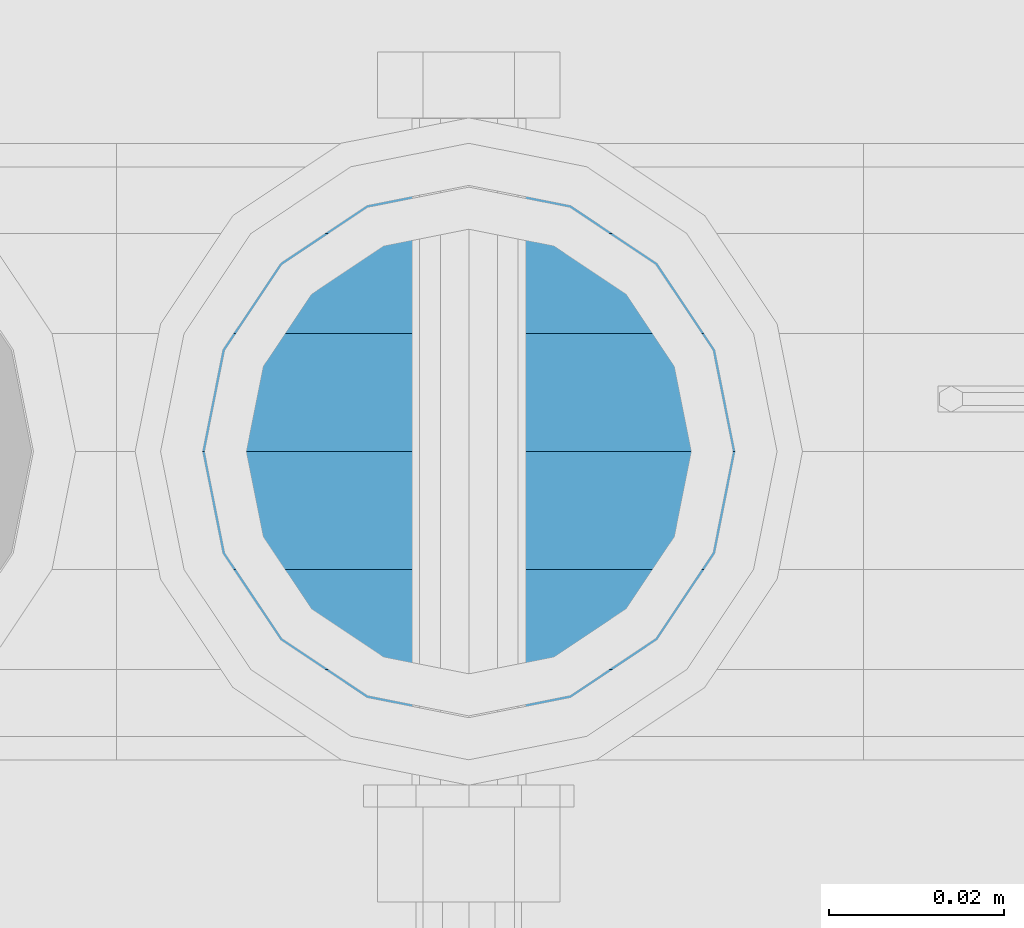
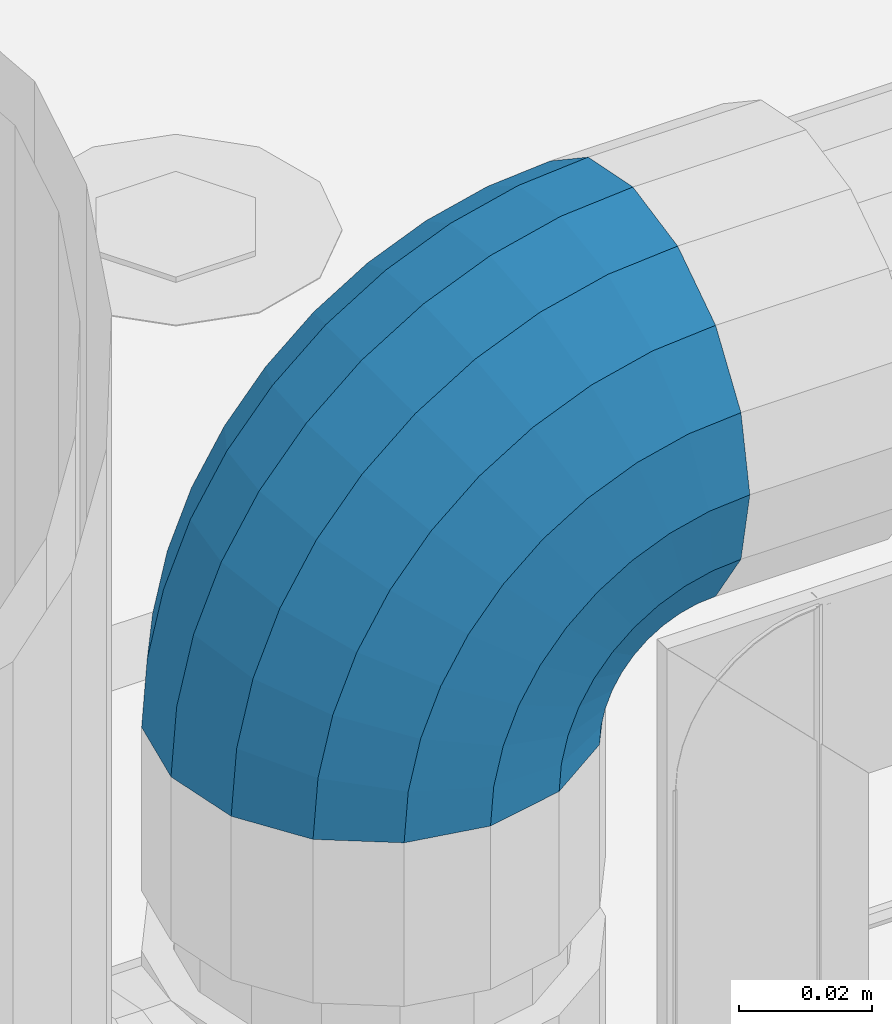
# One storey, part 146 of 247: 1 member.
"""IFC2X3 building model written with IfcOpenShell, lengths in millimetres."""

from ifc_helpers import new_model, si_unit, frame, origin_with_axes, place, context, subcontext, project, spatial, faceted_brep, material, type_object, element, save


model = new_model("IFC2X3")

# Units and contexts
model_context = context("Model", 3, precision=1e-05, world=origin_with_axes())
body_context = subcontext(model_context, "Body", "Model", "MODEL_VIEW")
ifc_project = project(units=[si_unit("LENGTHUNIT", "METRE", prefix="MILLI"), si_unit("AREAUNIT", "SQUARE_METRE"), si_unit("VOLUMEUNIT", "CUBIC_METRE"), si_unit("MASSUNIT", "GRAM", prefix="KILO"), si_unit("TIMEUNIT", "SECOND"), si_unit("PLANEANGLEUNIT", "RADIAN"), si_unit("SOLIDANGLEUNIT", "STERADIAN"), si_unit("THERMODYNAMICTEMPERATUREUNIT", "DEGREE_CELSIUS"), si_unit("LUMINOUSINTENSITYUNIT", "LUMEN")], contexts=[model_context])

# Site, building, storey
site_placement = place(None, origin_with_axes())
site = spatial("IfcSite", under=ifc_project, at=site_placement, CompositionType="ELEMENT")
building_placement = place(site_placement, origin_with_axes())
building = spatial("IfcBuilding", under=site, at=building_placement, Name="Standard", CompositionType="ELEMENT")
storey_placement = place(building_placement, origin_with_axes())
storey = spatial("IfcBuildingStorey", under=building, at=storey_placement, Name="Undefined", CompositionType="ELEMENT", Elevation=0.0)

# Member
ifc_material = material(Name="Misc_Undefined")
member_type = type_object("IfcMemberType", PredefinedType="NOTDEFINED")
member_placement = place(storey_placement, frame((621.0, 7664.5, 924.849999999999), z_axis=(-0.707106789186492, 3.85000008583224e-07, 0.707106773186498), x_axis=(0.707106781186548, 0.0, 0.707106781186547)))
element("IfcMember", 1, at=member_placement, inside=storey, type_object=member_type, material=ifc_material, context=body_context, shape_type="Brep", body=[
    faceted_brep([(0.0, -35.1499999999996, 0.0), (9.51152146007007, -32.4743655677721, -9.51152146007007), (13.2759578763416, -32.4743655677721, -6.29638902527768), (5.36946880023424, -35.1499999999996, 4.58595959347804), (17.5750000000007, -24.8548033587067, -17.5750000000007), (19.9787556631127, -24.8548033587067, -15.5219987155633), (22.9628441077039, -13.4513226476329, -22.962844107702), (24.4574219585265, -13.4513226476329, -21.6863540323957), (24.8548033587067, 0.0, -24.8548033587067), (26.0301204183143, 0.0, -23.8509877588021), (22.9628441077039, 13.4513226476329, -22.962844107702), (24.4574219585265, 13.4513226476329, -21.6863540323957), (17.5750000000007, 24.8548033587067, -17.5750000000007), (19.9787556631127, 24.8548033587067, -15.5219987155633), (9.51152146007007, 32.4743655677721, -9.51152146007007), (13.2759578763416, 32.4743655677721, -6.29638902527768), (0.0, 35.1499999999996, 0.0), (5.36946880023424, 35.1499999999996, 4.58595959347804), (-9.51152146007007, 32.4743655677721, 9.51152146007007), (-2.53702027587133, 32.4743655677721, 15.4683082122338), (-17.5749999999989, 24.8548033587067, 17.5749999999989), (-9.23981806264237, 24.8548033587067, 24.6939179025194), (-22.962844107702, 13.4513226476329, 22.962844107702), (-13.718484358058, 13.4513226476329, 30.8582732193499), (-24.8548033587067, 0.0, 24.8548033587067), (-15.2911828178458, 0.0, 33.0229069457564), (-22.962844107702, -13.4513226476329, 22.962844107702), (-13.718484358058, -13.4513226476329, 30.8582732193499), (-17.5749999999989, -24.8548033587067, 17.5749999999989), (-9.23981806264237, -24.8548033587067, 24.6939179025194), (-9.51152146007007, -32.4743655677721, 9.51152146007007), (-2.53702027587133, -32.4743655677721, 15.4683082122338), (0.0, -30.3500000000004, 0.0), (-8.21265081971796, -28.0397438117179, 8.21265081971796), (-1.45732902223608, -28.0397438117179, 13.9822406910371), (5.36946880023424, -30.3500000000004, 4.58595959347804), (-15.1749999999993, -21.4606908090118, 15.1749999999993), (-7.24480876131202, -21.4606908090118, 21.948023168994), (-19.8270929919981, -11.6144421722802, 19.827092992), (-11.1118790903529, -11.6144421722802, 27.2705888550772), (-21.4606908090118, 0.0, 21.4606908090118), (-12.4698136068437, 0.0, 29.139625372758), (-19.8270929919981, 11.6144421722802, 19.827092992), (-11.1118790903529, 11.6144421722802, 27.2705888550772), (-15.1749999999993, 21.4606908090118, 15.1749999999993), (-7.24480876131202, 21.4606908090118, 21.948023168994), (-8.21265081971796, 28.0397438117179, 8.21265081971796), (-1.45732902223608, 28.0397438117179, 13.9822406910371), (0.0, 30.3500000000004, 0.0), (5.36946880023424, 30.3500000000004, 4.58595959347804), (8.21265081971978, 28.0397438117179, -8.21265081971796), (12.1962666227046, 28.0397438117179, -4.81032150408282), (15.1750000000011, 21.4606908090118, -15.1750000000011), (17.9837463617787, 21.4606908090118, -12.776103982038), (19.827092992, 11.6144421722802, -19.827092992), (21.8508166908214, 11.6144421722802, -18.0986696681211), (21.4606908090118, 0.0, -21.4606908090118), (23.2087512073122, 0.0, -19.9677061858038), (19.827092992, -11.6144421722802, -19.827092992), (21.8508166908214, -11.6144421722802, -18.0986696681211), (15.1750000000011, -21.4606908090118, -15.1750000000011), (17.9837463617787, -21.4606908090118, -12.776103982038), (8.21265081971978, -28.0397438117179, -8.21265081971796), (12.1962666227046, -28.0397438117179, -4.81032150408282), (17.4970053560719, -32.4743655677721, -3.70972780292141), (11.3902326651169, -35.1499999999996, 8.27548843508157), (22.6740772628636, -24.8548033587067, -13.8703035149447), (26.1332861179544, -13.4513226476329, -20.6593831546816), (27.347998730962, 0.0, -23.0433908901377), (26.1332861179544, 13.4513226476329, -20.6593831546816), (22.6740772628636, 24.8548033587067, -13.8703035149447), (17.4970053560719, 32.4743655677721, -3.70972780292141), (11.3902326651169, 35.1499999999996, 8.27548843508157), (5.28345997416, 32.4743655677721, 20.2607046730845), (0.106388067368243, 24.8548033587067, 30.4212803851096), (-3.3528207877207, 13.4513226476329, 37.2103600248429), (-4.56753340072828, 0.0, 39.5943677603027), (-3.3528207877207, -13.4513226476329, 37.2103600248429), (0.106388067368243, -24.8548033587067, 30.4212803851096), (5.28345997416, -32.4743655677721, 20.2607046730845), (6.11738625912767, -28.0397438117179, 18.6240321853929), (11.3902326651169, -30.3500000000004, 8.27548843508157), (1.64728291997744, -21.4606908090118, 27.3971039594999), (-1.33954464053386, -11.6144421722802, 33.2590831078905), (-2.38837900197905, 0.0, 35.3175364441977), (-1.33954464053386, 11.6144421722802, 33.2590831078905), (1.64728291997744, 21.4606908090118, 27.3971039594999), (6.11738625912767, 28.0397438117179, 18.6240321853929), (11.3902326651169, 30.3500000000004, 8.27548843508157), (16.663079071106, 28.0397438117179, -2.07305531522979), (21.1331824102544, 21.4606908090118, -10.8461270893367), (24.1200099707676, 11.6144421722802, -16.7081062377292), (25.1688443322109, 0.0, -18.7665595740345), (24.1200099707676, -11.6144421722802, -16.7081062377292), (21.1331824102544, -21.4606908090118, -10.8461270893367), (16.663079071106, -28.0397438117179, -2.07305531522979), (22.0707277014626, -32.4743655677721, -1.81522997693355), (17.9140404065238, -35.1499999999996, 10.9777380798878), (25.5945970362118, -24.8548033587067, -12.6605846156472), (27.9491712485105, -13.4513226476329, -19.9072189058952), (28.7759877588032, 0.0, -22.4518984678889), (27.9491712485105, 13.4513226476329, -19.9072189058952), (25.5945970362118, 24.8548033587067, -12.6605846156472), (22.0707277014626, 32.4743655677721, -1.81522997693355), (17.9140404065238, 35.1499999999996, 10.9777380798878), (13.757353111585, 32.4743655677721, 23.7707061367073), (10.2334837768358, 24.8548033587067, 34.6160607754209), (7.87890956453703, 13.4513226476329, 41.8626950656671), (7.05209305424432, 0.0, 44.4073746276608), (7.87890956453703, -13.4513226476329, 41.8626950656671), (10.2334837768358, -24.8548033587067, 34.6160607754209), (13.757353111585, -32.4743655677721, 23.7707061367073), (14.3249803951039, -28.0397438117179, 22.0237289909692), (17.9140404065238, -30.3500000000004, 10.9777380798878), (11.2823222355109, -21.4606908090118, 31.3880679179929), (9.24928305078174, -11.6144421722802, 37.6451191472679), (8.53537462724307, 0.0, 39.8423033494455), (9.24928305078174, 11.6144421722802, 37.6451191472679), (11.2823222355109, 21.4606908090118, 31.3880679179929), (14.3249803951039, 28.0397438117179, 22.0237289909692), (17.9140404065238, 30.3500000000004, 10.9777380798878), (21.5031004179418, 28.0397438117179, -0.0682528311936039), (24.5457585775348, 21.4606908090118, -9.43259175821731), (26.578797762264, 11.6144421722802, -15.6896429874942), (27.2927061858027, 0.0, -17.8868271896699), (26.578797762264, -11.6144421722802, -15.6896429874942), (24.5457585775348, -21.4606908090118, -9.43259175821731), (21.5031004179418, -28.0397438117179, -0.0682528311936039), (26.884504689051, -32.4743655677721, -0.65954437126311), (24.7802542265854, -35.1499999999996, 12.6261701733856), (28.6684020936846, -24.8548033587067, -11.9226293117936), (29.8603642317012, -13.4513226476329, -19.4483820661262), (30.2789256727501, 0.0, -22.0910749985342), (29.8603642317012, 13.4513226476329, -19.4483820661262), (28.6684020936846, 24.8548033587067, -11.9226293117936), (26.884504689051, 32.4743655677721, -0.65954437126311), (24.7802542265854, 35.1499999999996, 12.6261701733856), (22.6760037641197, 32.4743655677721, 25.9118847180362), (20.8921063594862, 24.8548033587067, 37.1749696585666), (19.7001442214696, 13.4513226476329, 44.7007224128993), (19.2815827804206, 0.0, 47.3434153453054), (19.7001442214696, -13.4513226476329, 44.7007224128993), (20.8921063594862, -24.8548033587067, 37.1749696585666), (22.6760037641197, -32.4743655677721, 25.9118847180362), (22.9633551786228, -28.0397438117179, 24.097619289465), (24.7802542265854, -30.3500000000004, 12.6261701733856), (21.4230625404816, -21.4606908090118, 33.8226442665655), (20.3938719035341, -11.6144421722802, 40.3206982094944), (20.0324682126138, 0.0, 42.6025113104479), (20.3938719035341, 11.6144421722802, 40.3206982094944), (21.4230625404816, 21.4606908090118, 33.8226442665655), (22.9633551786228, 28.0397438117179, 24.097619289465), (24.7802542265854, 30.3500000000004, 12.6261701733856), (26.5971532745461, 28.0397438117179, 1.15472105730987), (28.1374459126855, 21.4606908090118, -8.5703039197906), (29.1666365496367, 11.6144421722802, -15.0683578627213), (29.5280402405569, 0.0, -17.3501709636766), (29.1666365496367, -11.6144421722802, -15.0683578627213), (28.1374459126855, -21.4606908090118, -8.5703039197906), (26.5971532745461, -28.0397438117179, 1.15472105730987), (31.8198051533964, -32.4743655677721, -0.271127801028342), (31.8198051533946, -35.1499999999996, 13.1801948466054), (31.8198051533964, -24.8548033587067, -11.6746085121031), (31.8198051533964, -13.4513226476329, -19.2941707211648), (31.8198051533964, 0.0, -21.969805153396), (31.8198051533964, 13.4513226476329, -19.2941707211648), (31.8198051533964, 24.8548033587067, -11.6746085121031), (31.8198051533964, 32.4743655677721, -0.271127801028342), (31.8198051533946, 35.1499999999996, 13.1801948466054), (31.8198051533946, 32.4743655677721, 26.6315174942392), (31.8198051533946, 24.8548033587067, 38.0349982053121), (31.8198051533964, 13.4513226476329, 45.6545604143757), (31.8198051533964, 0.0, 48.3301948466033), (31.8198051533964, -13.4513226476329, 45.6545604143757), (31.8198051533946, -24.8548033587067, 38.0349982053121), (31.8198051533946, -32.4743655677721, 26.6315174942392), (31.8198051533964, -28.0397438117179, 24.7946370188838), (31.8198051533946, -30.3500000000004, 13.1801948466054), (31.8198051533964, -21.4606908090118, 34.6408856556172), (31.8198051533946, -11.6144421722802, 41.2199386583234), (31.8198051533964, 0.0, 43.530194846604), (31.8198051533946, 11.6144421722802, 41.2199386583234), (31.8198051533964, 21.4606908090118, 34.6408856556172), (31.8198051533964, 28.0397438117179, 24.7946370188838), (31.8198051533946, 30.3500000000004, 13.1801948466054), (31.8198051533964, 28.0397438117179, 1.56575267432345), (31.8198051533964, 21.4606908090118, -8.28049596240635), (31.8198051533946, 11.6144421722802, -14.8595489651125), (31.8198051533964, 0.0, -17.1698051533949), (31.8198051533946, -11.6144421722802, -14.8595489651125), (31.8198051533964, -21.4606908090118, -8.28049596240635), (31.8198051533964, -28.0397438117179, 1.56575267432345), (36.7551056177399, -32.4743655677721, -0.659544371264928), (38.8593560802055, -35.1499999999996, 12.6261701733874), (34.9712082131082, -24.8548033587067, -11.9226293117936), (33.7792460750934, -13.4513226476329, -19.4483820661262), (33.3606846340426, 0.0, -22.0910749985342), (33.7792460750934, 13.4513226476329, -19.4483820661262), (34.9712082131082, 24.8548033587067, -11.9226293117936), (36.7551056177399, 32.4743655677721, -0.659544371264928), (38.8593560802055, 35.1499999999996, 12.6261701733874), (40.963606542673, 32.4743655677721, 25.9118847180362), (42.7475039473047, 24.8548033587067, 37.1749696585666), (43.9394660853195, 13.4513226476329, 44.7007224128993), (44.3580275263703, 0.0, 47.3434153453054), (43.9394660853195, -13.4513226476329, 44.7007224128993), (42.7475039473047, -24.8548033587067, 37.1749696585666), (40.963606542673, -32.4743655677721, 25.9118847180362), (40.6762551281663, -28.0397438117179, 24.097619289465), (38.8593560802055, -30.3500000000004, 12.6261701733874), (42.2165477663093, -21.4606908090118, 33.8226442665637), (43.2457384032587, -11.6144421722802, 40.3206982094925), (43.6071420941771, 0.0, 42.6025113104497), (43.2457384032587, 11.6144421722802, 40.3206982094925), (42.2165477663093, 21.4606908090118, 33.8226442665637), (40.6762551281663, 28.0397438117179, 24.097619289465), (38.8593560802055, 30.3500000000004, 12.6261701733874), (37.0424570322448, 28.0397438117179, 1.15472105730805), (35.5021643941036, 21.4606908090118, -8.5703039197906), (34.4729737571543, 11.6144421722802, -15.0683578627213), (34.1115700662358, 0.0, -17.3501709636766), (34.4729737571543, -11.6144421722802, -15.0683578627213), (35.5021643941036, -21.4606908090118, -8.5703039197906), (37.0424570322448, -28.0397438117179, 1.15472105730805), (41.5688826053301, -32.4743655677721, -1.81522997693355), (45.725569900269, -35.1499999999996, 10.9777380798878), (38.045013270581, -24.8548033587067, -12.6605846156453), (35.6904390582822, -13.4513226476329, -19.9072189058934), (34.8636225479895, 0.0, -22.4518984678889), (35.6904390582822, 13.4513226476329, -19.9072189058934), (38.045013270581, 24.8548033587067, -12.6605846156453), (41.5688826053301, 32.4743655677721, -1.81522997693355), (45.725569900269, 35.1499999999996, 10.9777380798878), (49.8822571952078, 32.4743655677721, 23.7707061367073), (53.406126529957, 24.8548033587067, 34.6160607754209), (55.7607007422539, 13.4513226476329, 41.8626950656671), (56.5875172525484, 0.0, 44.4073746276608), (55.7607007422539, -13.4513226476329, 41.8626950656671), (53.406126529957, -24.8548033587067, 34.6160607754209), (49.8822571952078, -32.4743655677721, 23.7707061367073), (49.3146299116888, -28.0397438117179, 22.0237289909674), (45.725569900269, -30.3500000000004, 10.9777380798878), (52.35728807128, -21.4606908090118, 31.3880679179929), (54.3903272560092, -11.6144421722802, 37.6451191472679), (55.1042356795479, 0.0, 39.8423033494455), (54.3903272560092, 11.6144421722802, 37.6451191472679), (52.35728807128, 21.4606908090118, 31.3880679179929), (49.3146299116888, 28.0397438117179, 22.0237289909674), (45.725569900269, 30.3500000000004, 10.9777380798878), (42.1365098888491, 28.0397438117179, -0.0682528311936039), (39.0938517292579, 21.4606908090118, -9.43259175821913), (37.0608125445287, 11.6144421722802, -15.6896429874942), (36.3469041209901, 0.0, -17.8868271896699), (37.0608125445287, -11.6144421722802, -15.6896429874942), (39.0938517292579, -21.4606908090118, -9.43259175821913), (42.1365098888491, -28.0397438117179, -0.0682528311936039), (46.1426049507172, -32.4743655677721, -3.70972780292141), (52.2493776416759, -35.1499999999996, 8.27548843508157), (40.9655330439273, -24.8548033587067, -13.8703035149447), (37.5063241888383, -13.4513226476329, -20.6593831546816), (36.2916115758308, 0.0, -23.0433908901396), (37.5063241888383, 13.4513226476329, -20.6593831546816), (40.9655330439273, 24.8548033587067, -13.8703035149447), (46.1426049507172, 32.4743655677721, -3.70972780292141), (52.2493776416759, 35.1499999999996, 8.27548843508157), (58.3561503326328, 32.4743655677721, 20.2607046730845), (63.5332222394227, 24.8548033587067, 30.4212803851078), (66.9924310945134, 13.4513226476329, 37.2103600248447), (68.207143707521, 0.0, 39.5943677603027), (66.9924310945134, -13.4513226476329, 37.2103600248447), (63.5332222394227, -24.8548033587067, 30.4212803851078), (58.3561503326328, -32.4743655677721, 20.2607046730845), (57.5222240476651, -28.0397438117179, 18.6240321853929), (52.2493776416759, -30.3500000000004, 8.27548843508157), (61.9923273868153, -21.4606908090118, 27.3971039594999), (64.9791549473266, -11.6144421722802, 33.2590831078905), (66.0279893087718, 0.0, 35.3175364441995), (64.9791549473266, 11.6144421722802, 33.2590831078905), (61.9923273868153, 21.4606908090118, 27.3971039594999), (57.5222240476651, 28.0397438117179, 18.6240321853929), (52.2493776416759, 30.3500000000004, 8.27548843508157), (46.9765312356867, 28.0397438117179, -2.07305531522979), (42.5064278965383, 21.4606908090118, -10.8461270893367), (39.5196003360252, 11.6144421722802, -16.7081062377292), (38.47076597458, 0.0, -18.7665595740345), (39.5196003360252, -11.6144421722802, -16.7081062377292), (42.5064278965383, -21.4606908090118, -10.8461270893367), (46.9765312356867, -28.0397438117179, -2.07305531522979), (50.3636524304511, -32.4743655677721, -6.29638902527768), (58.2701415065567, -35.1499999999996, 4.58595959347804), (43.6608546436782, -24.8548033587067, -15.5219987155633), (39.1821883482662, -13.4513226476329, -21.6863540323939), (37.6094898884767, 0.0, -23.8509877588021), (39.1821883482662, 13.4513226476329, -21.6863540323939), (43.6608546436782, 24.8548033587067, -15.5219987155633), (50.3636524304511, 32.4743655677721, -6.29638902527768), (58.2701415065567, 35.1499999999996, 4.58595959347804), (66.1766305826623, 32.4743655677721, 15.4683082122338), (72.8794283694351, 24.8548033587067, 24.6939179025212), (77.3580946648472, 13.4513226476329, 30.8582732193499), (78.9307931246385, 0.0, 33.0229069457564), (77.3580946648472, -13.4513226476329, 30.8582732193499), (72.8794283694351, -24.8548033587067, 24.6939179025212), (66.1766305826623, -32.4743655677721, 15.4683082122338), (65.096939329027, -28.0397438117179, 13.9822406910371), (58.2701415065567, -30.3500000000004, 4.58595959347804), (70.8844190681029, -21.4606908090118, 21.948023168994), (74.7514893971438, -11.6144421722802, 27.2705888550772), (76.1094239136346, 0.0, 29.139625372758), (74.7514893971438, 11.6144421722802, 27.2705888550772), (70.8844190681029, 21.4606908090118, 21.948023168994), (65.096939329027, 28.0397438117179, 13.9822406910371), (58.2701415065567, 30.3500000000004, 4.58595959347804), (51.4433436840882, 28.0397438117179, -4.810321504081), (45.6558639450104, 21.4606908090118, -12.776103982038), (41.7887936159714, 11.6144421722802, -18.0986696681211), (40.4308590994806, 0.0, -19.9677061858019), (41.7887936159714, -11.6144421722802, -18.0986696681211), (45.6558639450104, -21.4606908090118, -12.776103982038), (51.4433436840882, -28.0397438117179, -4.810321504081), (54.1280888467209, -32.4743655677721, -9.51152146007007), (63.6396103067891, -35.1499999999996, 0.0), (46.0646103067902, -24.8548033587067, -17.5750000000007), (40.6767661990871, -13.4513226476329, -22.962844107702), (38.7848069480824, 0.0, -24.8548033587067), (40.6767661990871, 13.4513226476329, -22.962844107702), (46.0646103067902, 24.8548033587067, -17.5750000000007), (54.1280888467209, 32.4743655677721, -9.51152146007007), (63.6396103067891, 35.1499999999996, 0.0), (73.1511317668592, 32.4743655677721, 9.51152146007007), (81.2146103067898, 24.8548033587067, 17.5750000000007), (86.602454414493, 13.4513226476329, 22.962844107702), (88.4944136654976, 0.0, 24.8548033587067), (86.602454414493, -13.4513226476329, 22.962844107702), (81.2146103067898, -24.8548033587067, 17.5750000000007), (73.1511317668592, -32.4743655677721, 9.51152146007007), (71.8522611265089, -28.0397438117179, 8.21265081971796), (63.6396103067891, -30.3500000000004, 0.0), (78.8146103067902, -21.4606908090118, 15.1749999999993), (83.4667032987891, -11.6144421722802, 19.8270929919981), (85.1003011158009, 0.0, 21.4606908090118), (83.4667032987891, 11.6144421722802, 19.8270929919981), (78.8146103067902, 21.4606908090118, 15.1749999999993), (71.8522611265089, 28.0397438117179, 8.21265081971796), (63.6396103067891, 30.3500000000004, 0.0), (55.4269594870711, 28.0397438117179, -8.21265081971796), (48.4646103067898, 21.4606908090118, -15.1749999999993), (43.812517314791, 11.6144421722802, -19.8270929919981), (42.1789194977791, 0.0, -21.4606908090118), (43.812517314791, -11.6144421722802, -19.8270929919981), (48.4646103067898, -21.4606908090118, -15.1749999999993), (55.4269594870711, -28.0397438117179, -8.21265081971796)], [[[0, 1, 2, 3]], [[1, 4, 5, 2]], [[4, 6, 7, 5]], [[6, 8, 9, 7]], [[8, 10, 11, 9]], [[10, 12, 13, 11]], [[12, 14, 15, 13]], [[14, 16, 17, 15]], [[16, 18, 19, 17]], [[18, 20, 21, 19]], [[20, 22, 23, 21]], [[22, 24, 25, 23]], [[24, 26, 27, 25]], [[26, 28, 29, 27]], [[28, 30, 31, 29]], [[30, 0, 3, 31]], [[32, 33, 34, 35]], [[33, 36, 37, 34]], [[36, 38, 39, 37]], [[38, 40, 41, 39]], [[40, 42, 43, 41]], [[42, 44, 45, 43]], [[44, 46, 47, 45]], [[46, 48, 49, 47]], [[48, 50, 51, 49]], [[50, 52, 53, 51]], [[52, 54, 55, 53]], [[54, 56, 57, 55]], [[56, 58, 59, 57]], [[58, 60, 61, 59]], [[60, 62, 63, 61]], [[62, 32, 35, 63]], [[30, 28, 26, 24, 22, 20, 18, 16, 14, 12, 10, 8, 6, 4, 1, 0], [62, 60, 58, 56, 54, 52, 50, 48, 46, 44, 42, 40, 38, 36, 33, 32]], [[3, 2, 64, 65]], [[2, 5, 66, 64]], [[5, 7, 67, 66]], [[7, 9, 68, 67]], [[9, 11, 69, 68]], [[11, 13, 70, 69]], [[13, 15, 71, 70]], [[15, 17, 72, 71]], [[17, 19, 73, 72]], [[19, 21, 74, 73]], [[21, 23, 75, 74]], [[23, 25, 76, 75]], [[25, 27, 77, 76]], [[27, 29, 78, 77]], [[29, 31, 79, 78]], [[31, 3, 65, 79]], [[35, 34, 80, 81]], [[34, 37, 82, 80]], [[37, 39, 83, 82]], [[39, 41, 84, 83]], [[41, 43, 85, 84]], [[43, 45, 86, 85]], [[45, 47, 87, 86]], [[47, 49, 88, 87]], [[49, 51, 89, 88]], [[51, 53, 90, 89]], [[53, 55, 91, 90]], [[55, 57, 92, 91]], [[57, 59, 93, 92]], [[59, 61, 94, 93]], [[61, 63, 95, 94]], [[63, 35, 81, 95]], [[65, 64, 96, 97]], [[64, 66, 98, 96]], [[66, 67, 99, 98]], [[67, 68, 100, 99]], [[68, 69, 101, 100]], [[69, 70, 102, 101]], [[70, 71, 103, 102]], [[71, 72, 104, 103]], [[72, 73, 105, 104]], [[73, 74, 106, 105]], [[74, 75, 107, 106]], [[75, 76, 108, 107]], [[76, 77, 109, 108]], [[77, 78, 110, 109]], [[78, 79, 111, 110]], [[79, 65, 97, 111]], [[81, 80, 112, 113]], [[80, 82, 114, 112]], [[82, 83, 115, 114]], [[83, 84, 116, 115]], [[84, 85, 117, 116]], [[85, 86, 118, 117]], [[86, 87, 119, 118]], [[87, 88, 120, 119]], [[88, 89, 121, 120]], [[89, 90, 122, 121]], [[90, 91, 123, 122]], [[91, 92, 124, 123]], [[92, 93, 125, 124]], [[93, 94, 126, 125]], [[94, 95, 127, 126]], [[95, 81, 113, 127]], [[97, 96, 128, 129]], [[96, 98, 130, 128]], [[98, 99, 131, 130]], [[99, 100, 132, 131]], [[100, 101, 133, 132]], [[101, 102, 134, 133]], [[102, 103, 135, 134]], [[103, 104, 136, 135]], [[104, 105, 137, 136]], [[105, 106, 138, 137]], [[106, 107, 139, 138]], [[107, 108, 140, 139]], [[108, 109, 141, 140]], [[109, 110, 142, 141]], [[110, 111, 143, 142]], [[111, 97, 129, 143]], [[113, 112, 144, 145]], [[112, 114, 146, 144]], [[114, 115, 147, 146]], [[115, 116, 148, 147]], [[116, 117, 149, 148]], [[117, 118, 150, 149]], [[118, 119, 151, 150]], [[119, 120, 152, 151]], [[120, 121, 153, 152]], [[121, 122, 154, 153]], [[122, 123, 155, 154]], [[123, 124, 156, 155]], [[124, 125, 157, 156]], [[125, 126, 158, 157]], [[126, 127, 159, 158]], [[127, 113, 145, 159]], [[129, 128, 160, 161]], [[128, 130, 162, 160]], [[130, 131, 163, 162]], [[131, 132, 164, 163]], [[132, 133, 165, 164]], [[133, 134, 166, 165]], [[134, 135, 167, 166]], [[135, 136, 168, 167]], [[136, 137, 169, 168]], [[137, 138, 170, 169]], [[138, 139, 171, 170]], [[139, 140, 172, 171]], [[140, 141, 173, 172]], [[141, 142, 174, 173]], [[142, 143, 175, 174]], [[143, 129, 161, 175]], [[145, 144, 176, 177]], [[144, 146, 178, 176]], [[146, 147, 179, 178]], [[147, 148, 180, 179]], [[148, 149, 181, 180]], [[149, 150, 182, 181]], [[150, 151, 183, 182]], [[151, 152, 184, 183]], [[152, 153, 185, 184]], [[153, 154, 186, 185]], [[154, 155, 187, 186]], [[155, 156, 188, 187]], [[156, 157, 189, 188]], [[157, 158, 190, 189]], [[158, 159, 191, 190]], [[159, 145, 177, 191]], [[161, 160, 192, 193]], [[160, 162, 194, 192]], [[162, 163, 195, 194]], [[163, 164, 196, 195]], [[164, 165, 197, 196]], [[165, 166, 198, 197]], [[166, 167, 199, 198]], [[167, 168, 200, 199]], [[168, 169, 201, 200]], [[169, 170, 202, 201]], [[170, 171, 203, 202]], [[171, 172, 204, 203]], [[172, 173, 205, 204]], [[173, 174, 206, 205]], [[174, 175, 207, 206]], [[175, 161, 193, 207]], [[177, 176, 208, 209]], [[176, 178, 210, 208]], [[178, 179, 211, 210]], [[179, 180, 212, 211]], [[180, 181, 213, 212]], [[181, 182, 214, 213]], [[182, 183, 215, 214]], [[183, 184, 216, 215]], [[184, 185, 217, 216]], [[185, 186, 218, 217]], [[186, 187, 219, 218]], [[187, 188, 220, 219]], [[188, 189, 221, 220]], [[189, 190, 222, 221]], [[190, 191, 223, 222]], [[191, 177, 209, 223]], [[193, 192, 224, 225]], [[192, 194, 226, 224]], [[194, 195, 227, 226]], [[195, 196, 228, 227]], [[196, 197, 229, 228]], [[197, 198, 230, 229]], [[198, 199, 231, 230]], [[199, 200, 232, 231]], [[200, 201, 233, 232]], [[201, 202, 234, 233]], [[202, 203, 235, 234]], [[203, 204, 236, 235]], [[204, 205, 237, 236]], [[205, 206, 238, 237]], [[206, 207, 239, 238]], [[207, 193, 225, 239]], [[209, 208, 240, 241]], [[208, 210, 242, 240]], [[210, 211, 243, 242]], [[211, 212, 244, 243]], [[212, 213, 245, 244]], [[213, 214, 246, 245]], [[214, 215, 247, 246]], [[215, 216, 248, 247]], [[216, 217, 249, 248]], [[217, 218, 250, 249]], [[218, 219, 251, 250]], [[219, 220, 252, 251]], [[220, 221, 253, 252]], [[221, 222, 254, 253]], [[222, 223, 255, 254]], [[223, 209, 241, 255]], [[225, 224, 256, 257]], [[224, 226, 258, 256]], [[226, 227, 259, 258]], [[227, 228, 260, 259]], [[228, 229, 261, 260]], [[229, 230, 262, 261]], [[230, 231, 263, 262]], [[231, 232, 264, 263]], [[232, 233, 265, 264]], [[233, 234, 266, 265]], [[234, 235, 267, 266]], [[235, 236, 268, 267]], [[236, 237, 269, 268]], [[237, 238, 270, 269]], [[238, 239, 271, 270]], [[239, 225, 257, 271]], [[241, 240, 272, 273]], [[240, 242, 274, 272]], [[242, 243, 275, 274]], [[243, 244, 276, 275]], [[244, 245, 277, 276]], [[245, 246, 278, 277]], [[246, 247, 279, 278]], [[247, 248, 280, 279]], [[248, 249, 281, 280]], [[249, 250, 282, 281]], [[250, 251, 283, 282]], [[251, 252, 284, 283]], [[252, 253, 285, 284]], [[253, 254, 286, 285]], [[254, 255, 287, 286]], [[255, 241, 273, 287]], [[257, 256, 288, 289]], [[256, 258, 290, 288]], [[258, 259, 291, 290]], [[259, 260, 292, 291]], [[260, 261, 293, 292]], [[261, 262, 294, 293]], [[262, 263, 295, 294]], [[263, 264, 296, 295]], [[264, 265, 297, 296]], [[265, 266, 298, 297]], [[266, 267, 299, 298]], [[267, 268, 300, 299]], [[268, 269, 301, 300]], [[269, 270, 302, 301]], [[270, 271, 303, 302]], [[271, 257, 289, 303]], [[273, 272, 304, 305]], [[272, 274, 306, 304]], [[274, 275, 307, 306]], [[275, 276, 308, 307]], [[276, 277, 309, 308]], [[277, 278, 310, 309]], [[278, 279, 311, 310]], [[279, 280, 312, 311]], [[280, 281, 313, 312]], [[281, 282, 314, 313]], [[282, 283, 315, 314]], [[283, 284, 316, 315]], [[284, 285, 317, 316]], [[285, 286, 318, 317]], [[286, 287, 319, 318]], [[287, 273, 305, 319]], [[289, 288, 320, 321]], [[288, 290, 322, 320]], [[290, 291, 323, 322]], [[291, 292, 324, 323]], [[292, 293, 325, 324]], [[293, 294, 326, 325]], [[294, 295, 327, 326]], [[295, 296, 328, 327]], [[296, 297, 329, 328]], [[297, 298, 330, 329]], [[298, 299, 331, 330]], [[299, 300, 332, 331]], [[300, 301, 333, 332]], [[301, 302, 334, 333]], [[302, 303, 335, 334]], [[303, 289, 321, 335]], [[305, 304, 336, 337]], [[304, 306, 338, 336]], [[306, 307, 339, 338]], [[307, 308, 340, 339]], [[308, 309, 341, 340]], [[309, 310, 342, 341]], [[310, 311, 343, 342]], [[311, 312, 344, 343]], [[312, 313, 345, 344]], [[313, 314, 346, 345]], [[314, 315, 347, 346]], [[315, 316, 348, 347]], [[316, 317, 349, 348]], [[317, 318, 350, 349]], [[318, 319, 351, 350]], [[319, 305, 337, 351]], [[322, 323, 324, 325, 326, 327, 328, 329, 330, 331, 332, 333, 334, 335, 321, 320], [338, 339, 340, 341, 342, 343, 344, 345, 346, 347, 348, 349, 350, 351, 337, 336]]]),
])

save(model, "model.ifc")
